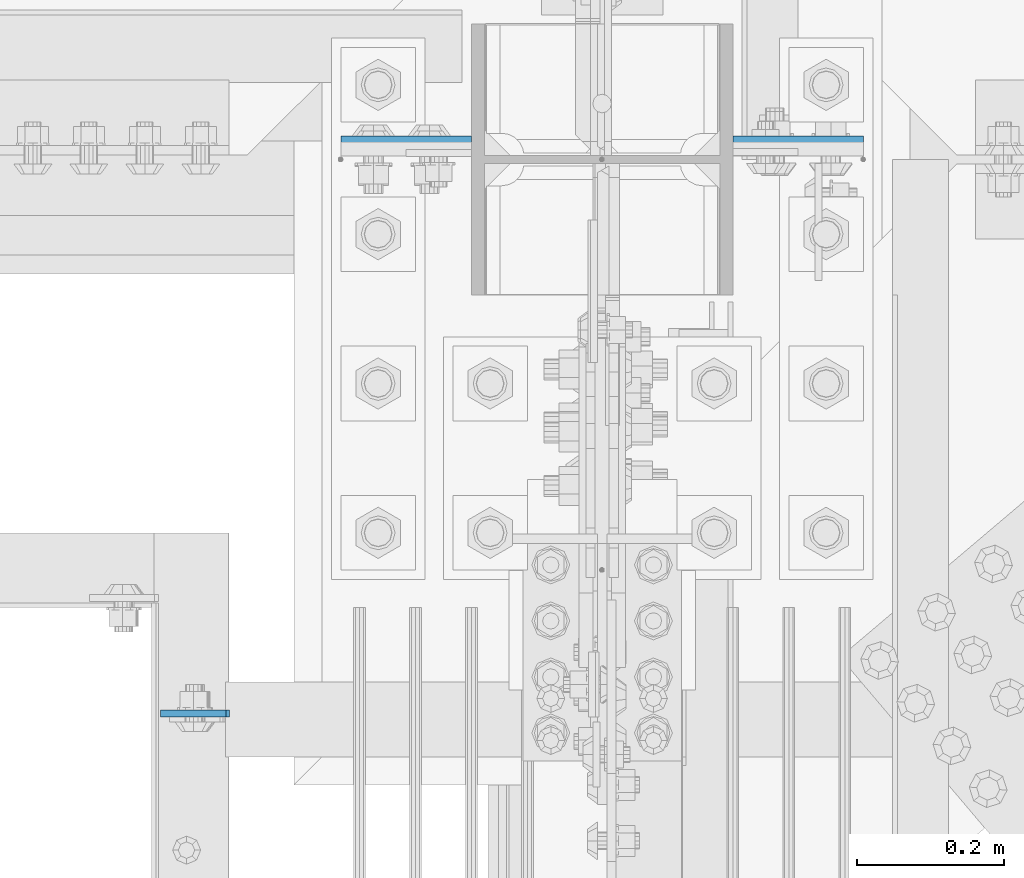
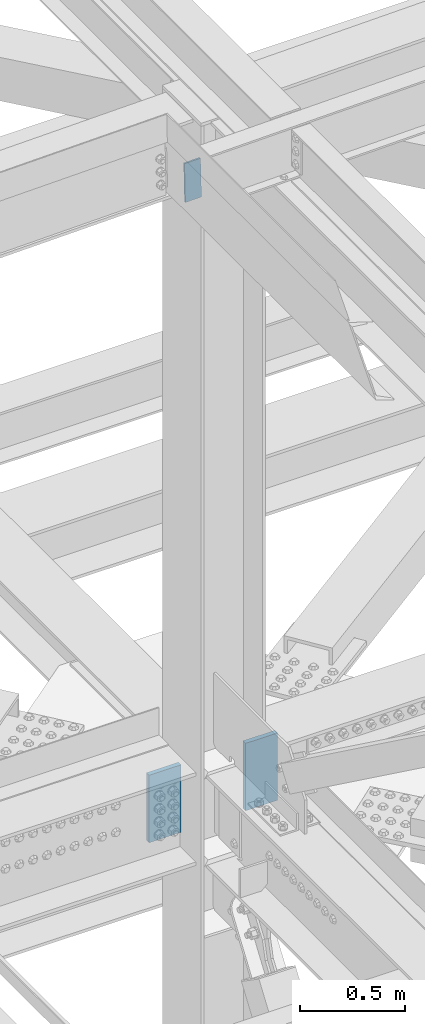
# One storey, part 3199 of 3843: 3 plates, 2 elements without a shape of their own.
"""IFC2X3 building model written with IfcOpenShell, lengths in millimetres."""

from ifc_helpers import new_model, si_unit, frame, origin_with_axes, place, context, subcontext, project, spatial, faceted_brep, material, type_object, element, aggregate, save


model = new_model("IFC2X3")

# Units and contexts
model_context = context("Model", 3, precision=1e-05, world=origin_with_axes())
body_context = subcontext(model_context, "Body", "Model", "MODEL_VIEW")
ifc_project = project(units=[si_unit("LENGTHUNIT", "METRE", prefix="MILLI"), si_unit("AREAUNIT", "SQUARE_METRE"), si_unit("VOLUMEUNIT", "CUBIC_METRE"), si_unit("MASSUNIT", "GRAM", prefix="KILO"), si_unit("TIMEUNIT", "SECOND"), si_unit("PLANEANGLEUNIT", "RADIAN"), si_unit("SOLIDANGLEUNIT", "STERADIAN"), si_unit("THERMODYNAMICTEMPERATUREUNIT", "DEGREE_CELSIUS"), si_unit("LUMINOUSINTENSITYUNIT", "LUMEN")], contexts=[model_context])

# Site, building, storey
site_placement = place(None, origin_with_axes())
site = spatial("IfcSite", under=ifc_project, at=site_placement, CompositionType="ELEMENT")
building_placement = place(site_placement, origin_with_axes())
building = spatial("IfcBuilding", under=site, at=building_placement, Name="Undefined", CompositionType="ELEMENT")
storey_placement = place(building_placement, origin_with_axes())
storey = spatial("IfcBuildingStorey", under=building, at=storey_placement, Name="Undefined", CompositionType="ELEMENT", Elevation=0.0)

# Assembly, plates
assembly_1_placement = place(storey_placement, origin_with_axes())
assembly_1 = element("IfcElementAssembly", 1, at=assembly_1_placement, inside=storey, Name="COLUMN", AssemblyPlace="NOTDEFINED", PredefinedType="RIGID_FRAME")
ifc_material = material(Name="STEEL/A572-50")
plate_type_1 = type_object("IfcPlateType", PredefinedType="NOTDEFINED")
plate_1_placement = place(assembly_1_placement, frame((77190.6, 25634.95, 42411.65), z_axis=(1.0, 0.0, 0.0), x_axis=(0.0, 0.0, -1.0)))
plate_1 = element("IfcPlate", 2, at=plate_1_placement, type_object=plate_type_1, material=ifc_material, Name="PLATE", context=body_context, shape_type="Brep", body=[
    faceted_brep([(0.0, -12.6999999999971, 0.0), (4.36557456851006e-11, -12.7000000000171, 177.800000000003), (-1.45519152283669e-11, 12.7000000000025, 177.800000000003), (0.0, 12.6999999999971, 0.0), (393.700012207031, -12.7000000000007, 177.800003051758), (393.700012207031, 12.7000000000007, 177.800003051758), (393.700012207031, -12.7000000000007, 0.0), (393.700012207031, 12.7000000000007, 0.0)], [[[0, 1, 2, 3]], [[1, 4, 5, 2]], [[4, 6, 7, 5]], [[6, 0, 3, 7]], [[5, 7, 3, 2]], [[6, 4, 1, 0]]]),
])
plate_2_placement = place(assembly_1_placement, frame((76835.0, 25634.95, 42411.65), z_axis=(-1.0, 0.0, 0.0), x_axis=(0.0, 0.0, -1.0)))
plate_2 = element("IfcPlate", 3, at=plate_2_placement, type_object=plate_type_1, material=ifc_material, Name="PLATE", context=body_context, shape_type="Brep", body=[
    faceted_brep([(0.0, -12.6999999999971, 0.0), (4.36557456851006e-11, -12.7000000000171, 177.800000000003), (-1.45519152283669e-11, 12.7000000000025, 177.800000000003), (0.0, 12.6999999999971, 0.0), (393.700012207031, -12.7000000000007, 177.800003051758), (393.700012207031, 12.7000000000007, 177.800003051758), (393.700012207031, -12.7000000000007, 0.0), (393.700012207031, 12.7000000000007, 0.0)], [[[0, 1, 2, 3]], [[1, 4, 5, 2]], [[4, 6, 7, 5]], [[6, 0, 3, 7]], [[5, 7, 3, 2]], [[6, 4, 1, 0]]]),
])
aggregate(assembly_1, [plate_1, plate_2])

# Assembly, plate
assembly_2_placement = place(storey_placement, origin_with_axes())
assembly_2 = element("IfcElementAssembly", 4, at=assembly_2_placement, inside=storey, Name="CHANNEL", AssemblyPlace="NOTDEFINED", PredefinedType="RIGID_FRAME")
plate_type_2 = type_object("IfcPlateType", PredefinedType="NOTDEFINED")
plate_3_placement = place(assembly_2_placement, frame((76411.9416336468, 24861.8374999989, 46534.2877178723), z_axis=(0.999776270257024, 0.0, 0.0211520550054619), x_axis=(0.0211520550054438, 0.0, -0.999776270257025)))
plate_3 = element("IfcPlate", 5, at=plate_3_placement, type_object=plate_type_2, material=ifc_material, Name="PLATE", context=body_context, shape_type="Brep", body=[
    faceted_brep([(0.0, -4.76249999999709, 0.0), (0.0, -4.76249999999709, 88.9000015258789), (0.0, 4.76249999999709, 88.9000015258789), (0.0, 4.76249999999709, 0.0), (228.600006102781, -4.7625000004191, 88.9000015257589), (228.600006102781, 4.76249999954598, 88.9000015257443), (228.600006103079, -4.7625000004482, 7.27595761418343e-12), (228.600006103079, 4.76249999954598, -7.27595761418343e-12)], [[[0, 1, 2, 3]], [[1, 4, 5, 2]], [[4, 6, 7, 5]], [[6, 0, 3, 7]], [[5, 7, 3, 2]], [[6, 4, 1, 0]]]),
])
aggregate(assembly_2, [plate_3])

save(model, "model.ifc")
